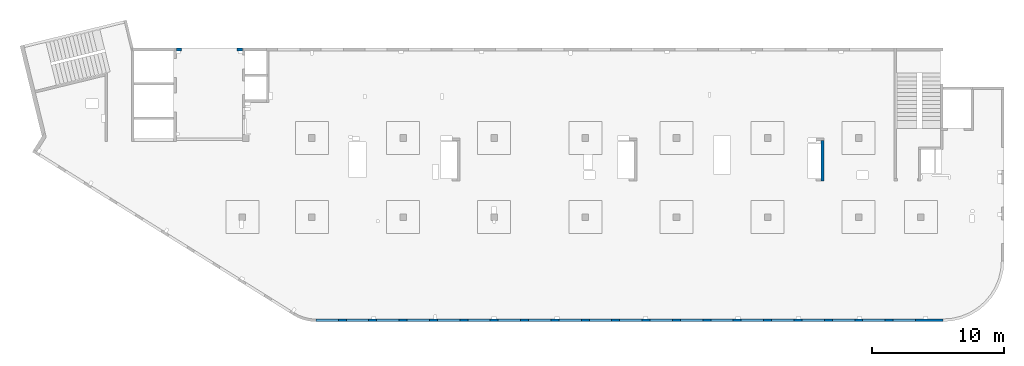
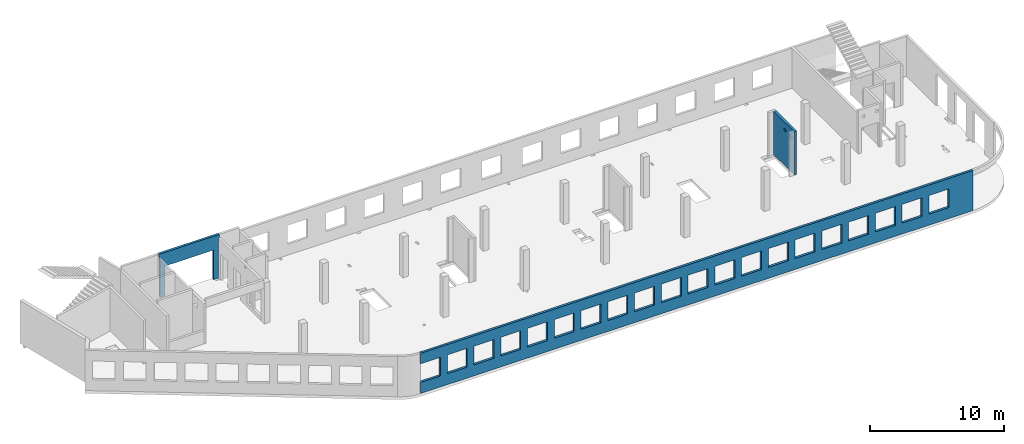
# One storey, part 5 of 6: 3 walls, 23 openings.
"""IFC4 building model written with IfcOpenShell, lengths in millimetres."""

from ifc_helpers import new_model, entity, si_unit, converted_unit, derived_unit, direction, frame, origin, place, context, subcontext, project, spatial, indexed_curve, outline, extrude, polygons, material, type_object, element, save


model = new_model("IFC4")

# Units and contexts
model_context = context("Model", 3, precision=0.01, world=origin(), true_north=direction((6.12303176911189e-17, 1.0)))
plan_context = context("Plan", 3, precision=0.01, world=origin(), true_north=direction((6.12303176911189e-17, 1.0)))
body_context = subcontext(model_context, "Body", "Model", "MODEL_VIEW")
ifc_project = project(units=[si_unit("LENGTHUNIT", "METRE", prefix="MILLI"), si_unit("AREAUNIT", "SQUARE_METRE"), si_unit("VOLUMEUNIT", "CUBIC_METRE"), converted_unit("PLANEANGLEUNIT", "DEGREE", entity("IfcRatioMeasure", 0.0174532925199433), si_unit("PLANEANGLEUNIT", "RADIAN"), dimensions=[0, 0, 0, 0, 0, 0, 0]), si_unit("MASSUNIT", "GRAM", prefix="KILO"), derived_unit("MASSDENSITYUNIT", [(si_unit("MASSUNIT", "GRAM", prefix="KILO"), 1), (si_unit("LENGTHUNIT", "METRE"), -3)]), derived_unit("MOMENTOFINERTIAUNIT", [(si_unit("LENGTHUNIT", "METRE"), 4)]), si_unit("TIMEUNIT", "SECOND"), si_unit("FREQUENCYUNIT", "HERTZ"), si_unit("THERMODYNAMICTEMPERATUREUNIT", "DEGREE_CELSIUS"), derived_unit("THERMALTRANSMITTANCEUNIT", [(si_unit("MASSUNIT", "GRAM", prefix="KILO"), 1), (si_unit("THERMODYNAMICTEMPERATUREUNIT", "KELVIN"), -1), (si_unit("TIMEUNIT", "SECOND"), -3)]), derived_unit("VOLUMETRICFLOWRATEUNIT", [(si_unit("LENGTHUNIT", "METRE"), 3), (si_unit("TIMEUNIT", "SECOND"), -1)]), derived_unit("MASSFLOWRATEUNIT", [(si_unit("MASSUNIT", "GRAM", prefix="KILO"), 1), (si_unit("TIMEUNIT", "SECOND"), -1)]), derived_unit("ROTATIONALFREQUENCYUNIT", [(si_unit("TIMEUNIT", "SECOND"), -1)]), si_unit("ELECTRICCURRENTUNIT", "AMPERE"), si_unit("ELECTRICVOLTAGEUNIT", "VOLT"), si_unit("POWERUNIT", "WATT"), si_unit("FORCEUNIT", "NEWTON", prefix="KILO"), si_unit("ILLUMINANCEUNIT", "LUX"), si_unit("LUMINOUSFLUXUNIT", "LUMEN"), si_unit("LUMINOUSINTENSITYUNIT", "CANDELA"), derived_unit("USERDEFINED", [(si_unit("MASSUNIT", "GRAM", prefix="KILO"), -1), (si_unit("LENGTHUNIT", "METRE"), -2), (si_unit("TIMEUNIT", "SECOND"), 3), (si_unit("LUMINOUSFLUXUNIT", "LUMEN"), 1)]), derived_unit("LINEARVELOCITYUNIT", [(si_unit("LENGTHUNIT", "METRE"), 1), (si_unit("TIMEUNIT", "SECOND"), -1)]), si_unit("PRESSUREUNIT", "PASCAL"), derived_unit("USERDEFINED", [(si_unit("LENGTHUNIT", "METRE"), -2), (si_unit("MASSUNIT", "GRAM", prefix="KILO"), 1), (si_unit("TIMEUNIT", "SECOND"), -2)]), derived_unit("LINEARFORCEUNIT", [(si_unit("MASSUNIT", "GRAM", prefix="KILO"), 1), (si_unit("LENGTHUNIT", "METRE"), 1), (si_unit("TIMEUNIT", "SECOND"), -2), (si_unit("LENGTHUNIT", "METRE"), -1)]), derived_unit("PLANARFORCEUNIT", [(si_unit("MASSUNIT", "GRAM", prefix="KILO"), 1), (si_unit("LENGTHUNIT", "METRE"), 1), (si_unit("TIMEUNIT", "SECOND"), -2), (si_unit("LENGTHUNIT", "METRE"), -2)])], contexts=[model_context, plan_context])

# Site, building, storey
site_placement = place(None, origin())
site = spatial("IfcSite", under=ifc_project, at=site_placement, CompositionType="ELEMENT")
building_placement = place(site_placement, origin())
building = spatial("IfcBuilding", under=site, at=building_placement, CompositionType="ELEMENT")
storey_placement = place(building_placement, frame((0.0, 0.0, 12000.0)))
storey = spatial("IfcBuildingStorey", under=building, at=storey_placement, Name="04", CompositionType="ELEMENT", Elevation=12000.0)

# Wall, openings
ifc_material = material()
wall_type = type_object("IfcWallType", Name=":ADSK_ 25_200", PredefinedType="STANDARD")
wall_1_placement = place(storey_placement, frame((68970.0, -100.0, -150.0), z_axis=(0.0, 0.0, 1.0), x_axis=(-1.0, 0.0, 0.0)))
wall_1 = element("IfcWall", 1, at=wall_1_placement, inside=storey, type_object=wall_type, material=ifc_material, Name=":ADSK_ 25_200", ObjectType=":ADSK_ 25_200", PredefinedType="NOTDEFINED", context=body_context, shape_type="Tessellation", body=[
    polygons([(8.66293717728731e-12, -100.0, 0.0), (47500.0, -100.0, 0.0), (47500.0, -100.0, 1000.00000000001), (45800.0, -100.000000000321, 1000.00000000001), (45800.0, -100.000000000321, 2699.99999999999), (47500.0, -100.0, 2699.99999999999), (47500.0, -100.0, 3650.0), (8.66293717728731e-12, -100.0, 3650.0), (1.42900165493394e-19, -100.0, 3200.0), (43500.0, -100.000000000321, 2700.0), (45200.0, -100.000000000321, 2700.0), (45200.0, -100.000000000321, 1000.00000000001), (43500.0, -100.000000000321, 1000.00000000001), (41200.0, -100.000000000321, 2700.0), (42900.0, -100.000000000321, 2700.0), (42900.0, -100.000000000321, 1000.00000000001), (41200.0, -100.000000000321, 1000.00000000001), (38900.0, -100.000000000321, 2700.0), (40600.0, -100.000000000321, 2700.0), (40600.0, -100.000000000321, 1000.00000000001), (38900.0, -100.000000000321, 1000.00000000001), (36600.0, -100.000000000321, 2700.0), (38300.0, -100.000000000321, 2700.0), (38300.0, -100.000000000321, 1000.00000000001), (36600.0, -100.000000000321, 1000.00000000001), (34300.0, -100.000000000321, 2700.0), (36000.0, -100.000000000321, 2700.0), (36000.0, -100.000000000321, 1000.00000000001), (34300.0, -100.000000000321, 1000.00000000001), (32000.0, -100.000000000321, 2700.0), (33700.0, -100.000000000321, 2700.0), (33700.0, -100.000000000321, 1000.00000000001), (32000.0, -100.000000000321, 1000.00000000001), (29700.0, -100.000000000321, 2700.0), (31400.0, -100.000000000321, 2700.0), (31400.0, -100.000000000321, 1000.00000000001), (29700.0, -100.000000000321, 1000.00000000001), (27400.0, -100.000000000321, 2700.0), (29100.0, -100.000000000321, 2700.0), (29100.0, -100.000000000321, 1000.00000000001), (27400.0, -100.000000000321, 1000.00000000001), (25100.0, -100.000000000321, 2700.0), (26800.0, -100.000000000321, 2700.0), (26800.0, -100.000000000321, 1000.00000000001), (25100.0, -100.000000000321, 1000.00000000001), (22800.0, -100.000000000321, 2700.0), (24500.0, -100.000000000321, 2700.0), (24500.0, -100.000000000321, 1000.00000000001), (22800.0, -100.000000000321, 1000.00000000001), (20500.0, -100.000000000321, 2700.0), (22200.0, -100.000000000321, 2700.0), (22200.0, -100.000000000321, 1000.00000000001), (20500.0, -100.000000000321, 1000.00000000001), (18200.0, -100.000000000321, 2700.0), (19900.0, -100.000000000321, 2700.0), (19900.0, -100.000000000321, 1000.00000000001), (18200.0, -100.000000000321, 1000.00000000001), (15900.0, -100.000000000321, 2700.0), (17600.0, -100.000000000321, 2700.0), (17600.0, -100.000000000321, 1000.00000000001), (15900.0, -100.000000000321, 1000.00000000001), (13600.0, -100.000000000321, 2700.0), (15300.0, -100.000000000321, 2700.0), (15300.0, -100.000000000321, 1000.00000000001), (13600.0, -100.000000000321, 1000.00000000001), (11300.0, -100.000000000321, 2700.0), (13000.0, -100.000000000321, 2700.0), (13000.0, -100.000000000321, 1000.00000000001), (11300.0, -100.000000000321, 1000.00000000001), (8999.99999999998, -100.000000000321, 2700.0), (10700.0, -100.000000000321, 2700.0), (10700.0, -100.000000000321, 1000.00000000001), (8999.99999999998, -100.000000000321, 1000.00000000001), (6699.99999999998, -100.000000000321, 2700.0), (8399.99999999997, -100.000000000321, 2700.0), (8399.99999999997, -100.000000000321, 1000.00000000001), (6699.99999999998, -100.000000000321, 1000.00000000001), (4399.99999999998, -100.000000000321, 2700.0), (6099.99999999997, -100.000000000321, 2700.0), (6099.99999999997, -100.000000000321, 1000.00000000001), (4399.99999999998, -100.000000000321, 1000.00000000001), (2099.99999999998, -100.000000000321, 2700.0), (3799.99999999998, -100.000000000321, 2700.0), (3799.99999999998, -100.000000000321, 1000.00000000001), (2099.99999999998, -100.000000000321, 1000.00000000001), (47500.0, 100.0, 0.0), (8.01671852045731e-12, 100.0, 0.0), (-6.46218513929826e-13, 100.0, 3200.0), (8.01671852045731e-12, 100.0, 3650.0), (47500.0, 100.0, 3650.0), (47500.0, 100.0, 2699.99999999999), (45800.0, 100.0, 2699.99999999999), (45800.0, 100.0, 1000.00000000001), (47500.0, 100.0, 1000.00000000001), (45200.0, 100.0, 2699.99999999999), (43500.0, 100.0, 2699.99999999999), (43500.0, 100.0, 1000.00000000001), (45200.0, 100.0, 1000.00000000001), (42900.0, 100.0, 2699.99999999999), (41200.0, 100.0, 2699.99999999999), (41200.0, 100.0, 1000.00000000001), (42900.0, 100.0, 1000.00000000001), (40600.0, 100.0, 2699.99999999999), (38900.0, 100.0, 2699.99999999999), (38900.0, 100.0, 1000.00000000001), (40600.0, 100.0, 1000.00000000001), (38300.0, 100.0, 2699.99999999999), (36600.0, 100.0, 2699.99999999999), (36600.0, 100.0, 1000.00000000001), (38300.0, 100.0, 1000.00000000001), (36000.0, 100.0, 2699.99999999999), (34300.0, 100.0, 2699.99999999999), (34300.0, 100.0, 1000.00000000001), (36000.0, 100.0, 1000.00000000001), (33700.0, 100.0, 2699.99999999999), (32000.0, 100.0, 2699.99999999999), (32000.0, 100.0, 1000.00000000001), (33700.0, 100.0, 1000.00000000001), (31400.0, 100.0, 2699.99999999999), (29700.0, 100.0, 2699.99999999999), (29700.0, 100.0, 1000.00000000001), (31400.0, 100.0, 1000.00000000001), (29100.0, 100.0, 2699.99999999999), (27400.0, 100.0, 2699.99999999999), (27400.0, 100.0, 1000.00000000001), (29100.0, 100.0, 1000.00000000001), (26800.0, 100.0, 2699.99999999999), (25100.0, 100.0, 2699.99999999999), (25100.0, 100.0, 1000.00000000001), (26800.0, 100.0, 1000.00000000001), (24500.0, 100.0, 2699.99999999999), (22800.0, 100.0, 2699.99999999999), (22800.0, 100.0, 1000.00000000001), (24500.0, 100.0, 1000.00000000001), (22200.0, 100.0, 2699.99999999999), (20500.0, 100.0, 2699.99999999999), (20500.0, 100.0, 1000.00000000001), (22200.0, 100.0, 1000.00000000001), (19900.0, 100.0, 2699.99999999999), (18200.0, 100.0, 2699.99999999999), (18200.0, 100.0, 1000.00000000001), (19900.0, 100.0, 1000.00000000001), (17600.0, 100.0, 2699.99999999999), (15900.0, 100.0, 2699.99999999999), (15900.0, 100.0, 1000.00000000001), (17600.0, 100.0, 1000.00000000001), (15300.0, 100.0, 2699.99999999999), (13600.0, 100.0, 2699.99999999999), (13600.0, 100.0, 1000.00000000001), (15300.0, 100.0, 1000.00000000001), (13000.0, 100.0, 2699.99999999999), (11300.0, 100.0, 2699.99999999999), (11300.0, 100.0, 1000.00000000001), (13000.0, 100.0, 1000.00000000001), (10700.0, 100.0, 2699.99999999999), (8999.99999999998, 100.0, 2699.99999999999), (8999.99999999998, 100.0, 1000.00000000001), (10700.0, 100.0, 1000.00000000001), (8399.99999999997, 100.0, 2699.99999999999), (6699.99999999997, 100.0, 2699.99999999999), (6699.99999999997, 100.0, 1000.00000000001), (8399.99999999997, 100.0, 1000.00000000001), (6099.99999999997, 100.0, 2699.99999999999), (4399.99999999998, 100.0, 2699.99999999999), (4399.99999999998, 100.0, 1000.00000000001), (6099.99999999997, 100.0, 1000.00000000001), (3799.99999999998, 100.0, 2699.99999999999), (2099.99999999998, 100.0, 2699.99999999999), (2099.99999999998, 100.0, 1000.00000000001), (3799.99999999998, 100.0, 1000.00000000001)], [[[1, 2, 3, 4, 5, 6, 7, 8, 9], [10, 11, 12, 13], [14, 15, 16, 17], [18, 19, 20, 21], [22, 23, 24, 25], [26, 27, 28, 29], [30, 31, 32, 33], [34, 35, 36, 37], [38, 39, 40, 41], [42, 43, 44, 45], [46, 47, 48, 49], [50, 51, 52, 53], [54, 55, 56, 57], [58, 59, 60, 61], [62, 63, 64, 65], [66, 67, 68, 69], [70, 71, 72, 73], [74, 75, 76, 77], [78, 79, 80, 81], [82, 83, 84, 85]], [[86, 87, 88, 89, 90, 91, 92, 93, 94], [95, 96, 97, 98], [99, 100, 101, 102], [103, 104, 105, 106], [107, 108, 109, 110], [111, 112, 113, 114], [115, 116, 117, 118], [119, 120, 121, 122], [123, 124, 125, 126], [127, 128, 129, 130], [131, 132, 133, 134], [135, 136, 137, 138], [139, 140, 141, 142], [143, 144, 145, 146], [147, 148, 149, 150], [151, 152, 153, 154], [155, 156, 157, 158], [159, 160, 161, 162], [163, 164, 165, 166], [167, 168, 169, 170]], [[2, 1, 87, 86]], [[2, 86, 94, 3]], [[8, 7, 90, 89]], [[1, 9, 8, 89, 88, 87]], [[5, 92, 91, 6]], [[93, 4, 3, 94]], [[92, 5, 4, 93]], [[11, 10, 96, 95]], [[11, 95, 98, 12]], [[12, 98, 97, 13]], [[96, 10, 13, 97]], [[15, 14, 100, 99]], [[15, 99, 102, 16]], [[16, 102, 101, 17]], [[100, 14, 17, 101]], [[19, 18, 104, 103]], [[19, 103, 106, 20]], [[20, 106, 105, 21]], [[104, 18, 21, 105]], [[23, 22, 108, 107]], [[23, 107, 110, 24]], [[24, 110, 109, 25]], [[108, 22, 25, 109]], [[27, 26, 112, 111]], [[27, 111, 114, 28]], [[28, 114, 113, 29]], [[112, 26, 29, 113]], [[31, 30, 116, 115]], [[31, 115, 118, 32]], [[32, 118, 117, 33]], [[116, 30, 33, 117]], [[35, 34, 120, 119]], [[35, 119, 122, 36]], [[36, 122, 121, 37]], [[120, 34, 37, 121]], [[39, 38, 124, 123]], [[39, 123, 126, 40]], [[40, 126, 125, 41]], [[124, 38, 41, 125]], [[43, 42, 128, 127]], [[43, 127, 130, 44]], [[44, 130, 129, 45]], [[128, 42, 45, 129]], [[47, 46, 132, 131]], [[47, 131, 134, 48]], [[48, 134, 133, 49]], [[132, 46, 49, 133]], [[51, 50, 136, 135]], [[51, 135, 138, 52]], [[52, 138, 137, 53]], [[136, 50, 53, 137]], [[55, 54, 140, 139]], [[55, 139, 142, 56]], [[56, 142, 141, 57]], [[140, 54, 57, 141]], [[59, 58, 144, 143]], [[59, 143, 146, 60]], [[60, 146, 145, 61]], [[144, 58, 61, 145]], [[63, 62, 148, 147]], [[63, 147, 150, 64]], [[64, 150, 149, 65]], [[148, 62, 65, 149]], [[67, 66, 152, 151]], [[67, 151, 154, 68]], [[68, 154, 153, 69]], [[152, 66, 69, 153]], [[71, 70, 156, 155]], [[71, 155, 158, 72]], [[72, 158, 157, 73]], [[156, 70, 73, 157]], [[75, 74, 160, 159]], [[75, 159, 162, 76]], [[76, 162, 161, 77]], [[160, 74, 77, 161]], [[79, 78, 164, 163]], [[79, 163, 166, 80]], [[80, 166, 165, 81]], [[164, 78, 81, 165]], [[83, 82, 168, 167]], [[83, 167, 170, 84]], [[84, 170, 169, 85]], [[168, 82, 85, 169]], [[90, 7, 6, 91]]], closed=True),
])
placement_1 = place(wall_1_placement, frame((68970.0, -100.0, 150.0), z_axis=(0.0, 0.0, 1.0), x_axis=(-1.0, 0.0, 0.0)))
element("IfcOpeningElement", 2, at=placement_1, cuts=wall_1, Name=":ADSK_ 25_200", PredefinedType="OPENING", context=body_context, shape_type="SweptSolid", body=[
    extrude(outline(indexed_curve([(-850.000000000002, -849.999999999995), (849.999999999997, -849.999999999995), (849.999999999997, 849.999999999993), (-850.000000000002, 849.999999999993), (-850.000000000002, -849.999999999995)], self_intersect=False)), frame((22320.0, 0.0, 1700.0), z_axis=(0.0, -1.0, 0.0), x_axis=(-1.0, 0.0, 0.0)), (0.0, 0.0, 1.0), 200.000000000962),
])
element("IfcOpeningElement", 3, at=placement_1, cuts=wall_1, Name=":ADSK_ 25_200", PredefinedType="OPENING", context=body_context, shape_type="SweptSolid", body=[
    extrude(outline(indexed_curve([(-849.999999999997, -849.999999999995), (850.000000000006, -849.999999999995), (850.000000000006, 849.999999999993), (-849.999999999997, 849.999999999993), (-849.999999999997, -849.999999999995)], self_intersect=False)), frame((66020.0, 0.0, 1700.0), z_axis=(0.0, -1.0, 0.0), x_axis=(-1.0, 0.0, 0.0)), (0.0, 0.0, 1.0), 200.000000000962),
])
element("IfcOpeningElement", 4, at=placement_1, cuts=wall_1, Name=":ADSK_ 25_200", PredefinedType="OPENING", context=body_context, shape_type="SweptSolid", body=[
    extrude(outline(indexed_curve([(-849.999999999997, -849.999999999995), (850.000000000006, -849.999999999995), (850.000000000006, 849.999999999993), (-849.999999999997, 849.999999999993), (-849.999999999997, -849.999999999995)], self_intersect=False)), frame((63720.0, 0.0, 1700.0), z_axis=(0.0, -1.0, 0.0), x_axis=(-1.0, 0.0, 0.0)), (0.0, 0.0, 1.0), 200.000000000962),
])
element("IfcOpeningElement", 5, at=placement_1, cuts=wall_1, Name=":ADSK_ 25_200", PredefinedType="OPENING", context=body_context, shape_type="SweptSolid", body=[
    extrude(outline(indexed_curve([(-849.999999999997, -849.999999999995), (850.000000000006, -849.999999999995), (850.000000000006, 849.999999999993), (-849.999999999997, 849.999999999993), (-849.999999999997, -849.999999999995)], self_intersect=False)), frame((61420.0, 0.0, 1700.0), z_axis=(0.0, -1.0, 0.0), x_axis=(-1.0, 0.0, 0.0)), (0.0, 0.0, 1.0), 200.000000000962),
])
element("IfcOpeningElement", 6, at=placement_1, cuts=wall_1, Name=":ADSK_ 25_200", PredefinedType="OPENING", context=body_context, shape_type="SweptSolid", body=[
    extrude(outline(indexed_curve([(-849.999999999997, -849.999999999995), (850.000000000006, -849.999999999995), (850.000000000006, 849.999999999993), (-849.999999999997, 849.999999999993), (-849.999999999997, -849.999999999995)], self_intersect=False)), frame((59120.0, 0.0, 1700.0), z_axis=(0.0, -1.0, 0.0), x_axis=(-1.0, 0.0, 0.0)), (0.0, 0.0, 1.0), 200.000000000962),
])
element("IfcOpeningElement", 7, at=placement_1, cuts=wall_1, Name=":ADSK_ 25_200", PredefinedType="OPENING", context=body_context, shape_type="SweptSolid", body=[
    extrude(outline(indexed_curve([(-849.999999999997, -849.999999999995), (850.000000000006, -849.999999999995), (850.000000000006, 849.999999999993), (-849.999999999997, 849.999999999993), (-849.999999999997, -849.999999999995)], self_intersect=False)), frame((56820.0, 0.0, 1700.0), z_axis=(0.0, -1.0, 0.0), x_axis=(-1.0, 0.0, 0.0)), (0.0, 0.0, 1.0), 200.000000000962),
])
element("IfcOpeningElement", 8, at=placement_1, cuts=wall_1, Name=":ADSK_ 25_200", PredefinedType="OPENING", context=body_context, shape_type="SweptSolid", body=[
    extrude(outline(indexed_curve([(-849.999999999997, -849.999999999995), (850.000000000006, -849.999999999995), (850.000000000006, 849.999999999993), (-849.999999999997, 849.999999999993), (-849.999999999997, -849.999999999995)], self_intersect=False)), frame((54520.0, 0.0, 1700.0), z_axis=(0.0, -1.0, 0.0), x_axis=(-1.0, 0.0, 0.0)), (0.0, 0.0, 1.0), 200.000000000962),
])
element("IfcOpeningElement", 9, at=placement_1, cuts=wall_1, Name=":ADSK_ 25_200", PredefinedType="OPENING", context=body_context, shape_type="SweptSolid", body=[
    extrude(outline(indexed_curve([(-849.999999999997, -849.999999999995), (850.000000000006, -849.999999999995), (850.000000000006, 849.999999999993), (-849.999999999997, 849.999999999993), (-849.999999999997, -849.999999999995)], self_intersect=False)), frame((52220.0, 0.0, 1700.0), z_axis=(0.0, -1.0, 0.0), x_axis=(-1.0, 0.0, 0.0)), (0.0, 0.0, 1.0), 200.000000000962),
])
element("IfcOpeningElement", 10, at=placement_1, cuts=wall_1, Name=":ADSK_ 25_200", PredefinedType="OPENING", context=body_context, shape_type="SweptSolid", body=[
    extrude(outline(indexed_curve([(-849.999999999997, -849.999999999995), (850.000000000006, -849.999999999995), (850.000000000006, 849.999999999993), (-849.999999999997, 849.999999999993), (-849.999999999997, -849.999999999995)], self_intersect=False)), frame((49920.0, 0.0, 1700.0), z_axis=(0.0, -1.0, 0.0), x_axis=(-1.0, 0.0, 0.0)), (0.0, 0.0, 1.0), 200.000000000962),
])
element("IfcOpeningElement", 11, at=placement_1, cuts=wall_1, Name=":ADSK_ 25_200", PredefinedType="OPENING", context=body_context, shape_type="SweptSolid", body=[
    extrude(outline(indexed_curve([(-849.999999999997, -849.999999999995), (850.000000000006, -849.999999999995), (850.000000000006, 849.999999999993), (-849.999999999997, 849.999999999993), (-849.999999999997, -849.999999999995)], self_intersect=False)), frame((47620.0, 0.0, 1700.0), z_axis=(0.0, -1.0, 0.0), x_axis=(-1.0, 0.0, 0.0)), (0.0, 0.0, 1.0), 200.000000000962),
])
element("IfcOpeningElement", 12, at=placement_1, cuts=wall_1, Name=":ADSK_ 25_200", PredefinedType="OPENING", context=body_context, shape_type="SweptSolid", body=[
    extrude(outline(indexed_curve([(-849.999999999997, -849.999999999995), (850.000000000006, -849.999999999995), (850.000000000006, 849.999999999993), (-849.999999999997, 849.999999999993), (-849.999999999997, -849.999999999995)], self_intersect=False)), frame((45320.0, 0.0, 1700.0), z_axis=(0.0, -1.0, 0.0), x_axis=(-1.0, 0.0, 0.0)), (0.0, 0.0, 1.0), 200.000000000962),
])
element("IfcOpeningElement", 13, at=placement_1, cuts=wall_1, Name=":ADSK_ 25_200", PredefinedType="OPENING", context=body_context, shape_type="SweptSolid", body=[
    extrude(outline(indexed_curve([(-849.999999999997, -849.999999999995), (850.000000000006, -849.999999999995), (850.000000000006, 849.999999999993), (-849.999999999997, 849.999999999993), (-849.999999999997, -849.999999999995)], self_intersect=False)), frame((43020.0, 0.0, 1700.0), z_axis=(0.0, -1.0, 0.0), x_axis=(-1.0, 0.0, 0.0)), (0.0, 0.0, 1.0), 200.000000000962),
])
element("IfcOpeningElement", 14, at=placement_1, cuts=wall_1, Name=":ADSK_ 25_200", PredefinedType="OPENING", context=body_context, shape_type="SweptSolid", body=[
    extrude(outline(indexed_curve([(-849.999999999997, -849.999999999995), (850.000000000006, -849.999999999995), (850.000000000006, 849.999999999993), (-849.999999999997, 849.999999999993), (-849.999999999997, -849.999999999995)], self_intersect=False)), frame((40720.0, 0.0, 1700.0), z_axis=(0.0, -1.0, 0.0), x_axis=(-1.0, 0.0, 0.0)), (0.0, 0.0, 1.0), 200.000000000962),
])
element("IfcOpeningElement", 15, at=placement_1, cuts=wall_1, Name=":ADSK_ 25_200", PredefinedType="OPENING", context=body_context, shape_type="SweptSolid", body=[
    extrude(outline(indexed_curve([(-849.999999999997, -849.999999999995), (850.000000000002, -849.999999999995), (850.000000000002, 849.999999999993), (-849.999999999997, 849.999999999993), (-849.999999999997, -849.999999999995)], self_intersect=False)), frame((38420.0, 0.0, 1700.0), z_axis=(0.0, -1.0, 0.0), x_axis=(-1.0, 0.0, 0.0)), (0.0, 0.0, 1.0), 200.000000000962),
])
element("IfcOpeningElement", 16, at=placement_1, cuts=wall_1, Name=":ADSK_ 25_200", PredefinedType="OPENING", context=body_context, shape_type="SweptSolid", body=[
    extrude(outline(indexed_curve([(-849.999999999997, -849.999999999995), (850.000000000002, -849.999999999995), (850.000000000002, 849.999999999993), (-849.999999999997, 849.999999999993), (-849.999999999997, -849.999999999995)], self_intersect=False)), frame((36120.0, 0.0, 1700.0), z_axis=(0.0, -1.0, 0.0), x_axis=(-1.0, 0.0, 0.0)), (0.0, 0.0, 1.0), 200.000000000962),
])
element("IfcOpeningElement", 17, at=placement_1, cuts=wall_1, Name=":ADSK_ 25_200", PredefinedType="OPENING", context=body_context, shape_type="SweptSolid", body=[
    extrude(outline(indexed_curve([(-849.999999999997, -849.999999999995), (850.000000000002, -849.999999999995), (850.000000000002, 849.999999999993), (-849.999999999997, 849.999999999993), (-849.999999999997, -849.999999999995)], self_intersect=False)), frame((33820.0, 0.0, 1700.0), z_axis=(0.0, -1.0, 0.0), x_axis=(-1.0, 0.0, 0.0)), (0.0, 0.0, 1.0), 200.000000000962),
])
element("IfcOpeningElement", 18, at=placement_1, cuts=wall_1, Name=":ADSK_ 25_200", PredefinedType="OPENING", context=body_context, shape_type="SweptSolid", body=[
    extrude(outline(indexed_curve([(-849.999999999997, -849.999999999995), (850.000000000002, -849.999999999995), (850.000000000002, 849.999999999993), (-849.999999999997, 849.999999999993), (-849.999999999997, -849.999999999995)], self_intersect=False)), frame((31520.0, 0.0, 1700.0), z_axis=(0.0, -1.0, 0.0), x_axis=(-1.0, 0.0, 0.0)), (0.0, 0.0, 1.0), 200.000000000962),
])
element("IfcOpeningElement", 19, at=placement_1, cuts=wall_1, Name=":ADSK_ 25_200", PredefinedType="OPENING", context=body_context, shape_type="SweptSolid", body=[
    extrude(outline(indexed_curve([(-850.000000000002, -849.999999999995), (849.999999999997, -849.999999999995), (849.999999999997, 849.999999999993), (-850.000000000002, 849.999999999993), (-850.000000000002, -849.999999999995)], self_intersect=False)), frame((29220.0, 0.0, 1700.0), z_axis=(0.0, -1.0, 0.0), x_axis=(-1.0, 0.0, 0.0)), (0.0, 0.0, 1.0), 200.000000000962),
])
element("IfcOpeningElement", 20, at=placement_1, cuts=wall_1, Name=":ADSK_ 25_200", PredefinedType="OPENING", context=body_context, shape_type="SweptSolid", body=[
    extrude(outline(indexed_curve([(-850.000000000002, -849.999999999995), (849.999999999997, -849.999999999995), (849.999999999997, 849.999999999993), (-850.000000000002, 849.999999999993), (-850.000000000002, -849.999999999995)], self_intersect=False)), frame((26920.0, 0.0, 1700.0), z_axis=(0.0, -1.0, 0.0), x_axis=(-1.0, 0.0, 0.0)), (0.0, 0.0, 1.0), 200.000000000962),
])
element("IfcOpeningElement", 21, at=placement_1, cuts=wall_1, Name=":ADSK_ 25_200", PredefinedType="OPENING", context=body_context, shape_type="SweptSolid", body=[
    extrude(outline(indexed_curve([(-850.000000000002, -849.999999999995), (849.999999999997, -849.999999999995), (849.999999999997, 849.999999999993), (-850.000000000002, 849.999999999993), (-850.000000000002, -849.999999999995)], self_intersect=False)), frame((24620.0, 0.0, 1700.0), z_axis=(0.0, -1.0, 0.0), x_axis=(-1.0, 0.0, 0.0)), (0.0, 0.0, 1.0), 200.000000000962),
])

# Wall, opening
wall_2_placement = place(storey_placement, frame((10800.0, 20400.0, -150.0)))
wall_2 = element("IfcWall", 22, at=wall_2_placement, inside=storey, type_object=wall_type, material=ifc_material, Name=":ADSK_ 25_200", ObjectType=":ADSK_ 25_200", PredefinedType="NOTDEFINED", context=body_context, shape_type="Tessellation", body=[
    polygons([(5200.00000000001, -100.000000000003, 3950.0), (5100.00000000001, -100.000000000003, 3950.0), (100.000000000001, -100.000000000003, 3950.0), (-4.99784381508401e-13, -100.000000000003, 3950.0), (-4.99784381508401e-13, -100.000000000003, 3900.0), (-4.99784381508401e-13, -100.000000000003, 3650.0), (100.000000000001, -100.000000000003, 3650.0), (100.000000000001, -100.000000000003, 0.0), (499.999999999992, -99.9999999999989, 0.0), (499.999999999994, -100.000000000003, 2699.99999999804), (4699.99999999999, -100.000000000003, 2699.99999999804), (4699.99999999999, -100.000000000003, 0.0), (5100.00000000001, -100.000000000003, 0.0), (5100.00000000001, -100.000000000003, 3650.0), (5200.00000000001, -100.000000000003, 3650.0), (5200.00000000001, -100.000000000003, 3900.0), (-1.16616415338434e-12, 99.9999999999989, 3950.0), (99.9999999999999, 99.9999999999989, 3950.0), (5100.0, 99.9999999999989, 3950.0), (5200.00000000001, 99.9999999999989, 3950.0), (5200.00000000001, 99.9999999999989, 3900.0), (5200.00000000001, 99.9999999999989, 3650.0), (5100.0, 99.9999999999989, 3650.0), (5100.0, 99.9999999999989, 49.9999999999973), (5100.0, 99.9999999999989, 0.0), (4699.99999999999, 99.9999999999989, 0.0), (4699.99999999999, 99.9999999999989, 2699.99999999804), (499.999999999993, 100.000000000003, 2699.99999999804), (499.999999999993, 100.000000000003, 0.0), (99.9999999999999, 99.9999999999989, 0.0), (99.9999999999999, 99.9999999999989, 49.9999999999973), (99.9999999999999, 99.9999999999989, 3650.0), (-1.16616415338434e-12, 99.9999999999989, 3650.0), (-1.16616415338434e-12, 99.9999999999989, 3900.0)], [[[1, 2, 3, 4, 5, 6, 7, 8, 9, 10, 11, 12, 13, 14, 15, 16]], [[17, 18, 19, 20, 21, 22, 23, 24, 25, 26, 27, 28, 29, 30, 31, 32, 33, 34]], [[8, 30, 29, 9]], [[4, 3, 2, 1, 20, 19, 18, 17]], [[10, 28, 27, 11]], [[11, 27, 26, 12]], [[28, 10, 9, 29]], [[20, 1, 16, 15, 22, 21]], [[13, 25, 24, 23, 14]], [[6, 33, 32, 7]], [[4, 17, 34, 33, 6, 5]], [[30, 8, 7, 32, 31]], [[22, 15, 14, 23]], [[25, 13, 12, 26]]], closed=True),
])
opening_21_placement = place(wall_2_placement, frame((-10800.0, -20400.0, 150.0)))
element("IfcOpeningElement", 23, at=opening_21_placement, cuts=wall_2, Name=":ADSK_ 25_200", PredefinedType="OPENING", context=body_context, shape_type="SweptSolid", body=[
    extrude(outline(indexed_curve([(-2100.0, -1349.99999999902), (2100.0, -1349.99999999902), (2100.0, 1349.99999999902), (-2100.0, 1349.99999999902), (-2100.0, -1349.99999999902)], self_intersect=False)), frame((13400.0, 20200.0, 1200.0), z_axis=(0.0, 1.0, 0.0), x_axis=(1.0, 0.0, 0.0)), (0.0, 0.0, 1.0), 400.000000001945),
])

# Wall, openings
wall_3_placement = place(storey_placement, frame((59830.0, 13500.0, -150.0), z_axis=(0.0, 0.0, 1.0), x_axis=(0.0, -1.0, 0.0)))
wall_3 = element("IfcWall", 24, at=wall_3_placement, inside=storey, type_object=wall_type, material=ifc_material, Name=":ADSK_ 25_200", ObjectType=":ADSK_ 25_200", PredefinedType="NOTDEFINED", context=body_context, shape_type="Tessellation", body=[
    polygons([(-2.16573425859679e-12, -99.999999999987, 0.0), (2875.00000000001, -99.9999999999967, 0.0), (3075.00000000001, -99.9999999999962, 0.0), (3075.00000000001, -99.9999999999962, 3950.0), (2875.00000000001, -99.9999999999967, 3950.0), (-2.16573425859679e-12, -99.999999999987, 3950.0), (1560.00000000001, -100.000000000009, 3400.0), (1810.00000000001, -100.000000000008, 3400.0), (1810.00000000001, -100.000000000008, 3150.00000000001), (1560.00000000001, -100.000000000009, 3150.00000000001), (2360.00000000001, -100.000000000007, 3330.0), (2710.00000000001, -100.000000000006, 3330.0), (2710.00000000001, -100.000000000006, 2980.00000000001), (2360.00000000001, -100.000000000007, 2980.00000000001), (-2.16573425859679e-12, 100.000000000002, 0.0), (-2.16573425859679e-12, 100.000000000002, 3950.0), (3075.00000000001, 99.999999999993, 3950.0), (3075.00000000001, 99.999999999993, 0.0), (1810.00000000001, 100.000000000319, 3400.0), (1560.00000000001, 100.000000000318, 3400.0), (1560.00000000001, 100.000000000318, 3150.00000000001), (1810.00000000001, 100.000000000319, 3150.00000000001), (2710.00000000001, 100.000000000321, 3330.0), (2360.00000000001, 100.00000000032, 3330.0), (2360.00000000001, 100.00000000032, 2980.00000000001), (2710.00000000001, 100.000000000321, 2980.00000000001)], [[[1, 2, 3, 4, 5, 6], [7, 8, 9, 10], [11, 12, 13, 14]], [[15, 16, 17, 18], [19, 20, 21, 22], [23, 24, 25, 26]], [[3, 2, 1, 15, 18]], [[6, 5, 4, 17, 16]], [[1, 6, 16, 15]], [[4, 3, 18, 17]], [[20, 19, 8, 7]], [[20, 7, 10, 21]], [[21, 10, 9, 22]], [[8, 19, 22, 9]], [[24, 23, 12, 11]], [[24, 11, 14, 25]], [[25, 14, 13, 26]], [[12, 23, 26, 13]]], closed=True),
])
placement_2 = place(wall_3_placement, frame((13500.0, -59830.0, 150.0), z_axis=(0.0, 0.0, 1.0), x_axis=(0.0, 1.0, 0.0)))
element("IfcOpeningElement", 25, at=placement_2, cuts=wall_3, Name=":ADSK_ 25_200", PredefinedType="OPENING", context=body_context, shape_type="SweptSolid", body=[
    extrude(outline(indexed_curve([(-174.999999999993, -174.999999999999), (174.999999999993, -174.999999999999), (174.999999999993, 175.000000000001), (-174.999999999993, 175.000000000001), (-174.999999999993, -174.999999999999)], self_intersect=False)), frame((59730.0, 10965.0, 3005.0), z_axis=(1.0, 0.0, 0.0), x_axis=(0.0, 0.0, -1.0)), (0.0, 0.0, 1.0), 200.000000000968),
])
element("IfcOpeningElement", 26, at=placement_2, cuts=wall_3, Name=":ADSK_ 25_200", PredefinedType="OPENING", context=body_context, shape_type="SweptSolid", body=[
    extrude(outline(indexed_curve([(-124.999999999991, -125.0), (124.999999999993, -125.0), (124.999999999993, 125.0), (-124.999999999991, 125.0), (-124.999999999991, -125.0)], self_intersect=False)), frame((59730.0, 11815.0, 3125.0), z_axis=(1.0, 0.0, 0.0), x_axis=(0.0, 0.0, -1.0)), (0.0, 0.0, 1.0), 200.000000000968),
])

save(model, "model.ifc")
